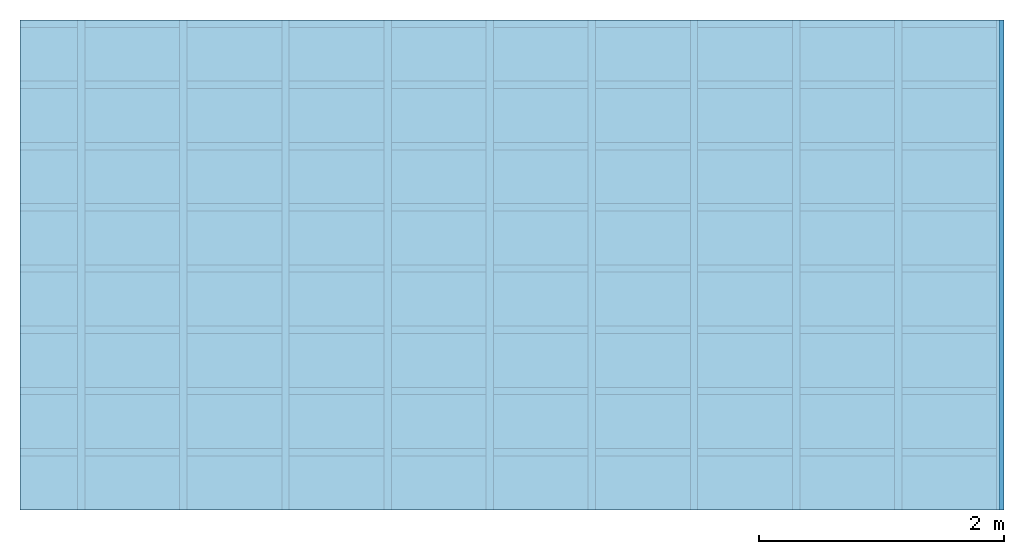
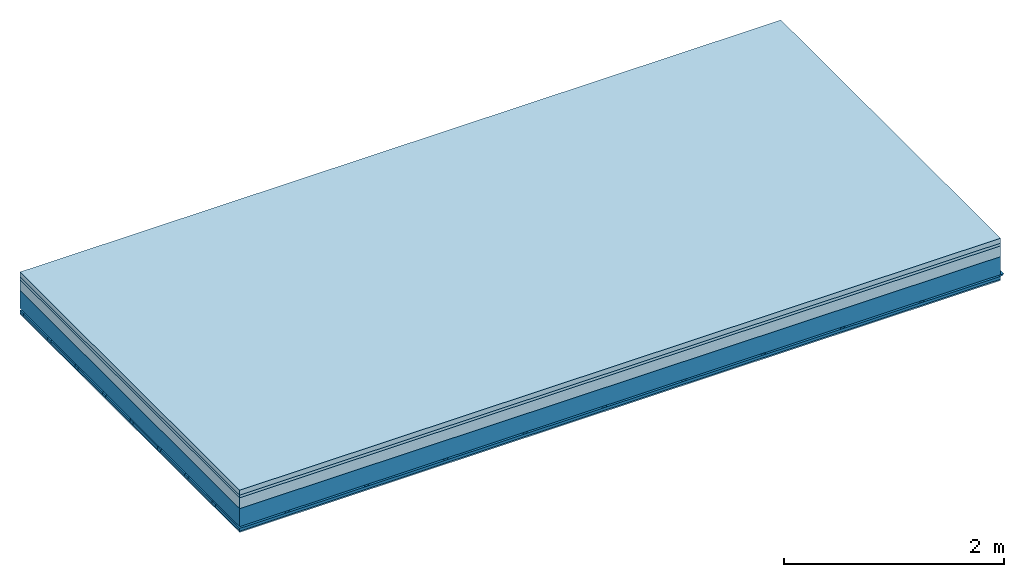
# One storey: 4 members, 4 plates, 1 element without a shape of its own.
"""IFC4 building model written with IfcOpenShell, lengths in metres."""

from ifc_helpers import new_model, si_unit, derived_unit, direction, frame, frame_2d, origin, origin_with_axes, place, context, project, spatial, polyline, rectangle, outline, extrude, material, layer, layer_set, type_object, element, aggregate, save


model = new_model("IFC4")

# Units and contexts
plan_context = context("Plan", 3, precision=1e-05, world=origin(), true_north=direction((0.0, 1.0)))
model_context = context("Model", 3, precision=1e-05, world=origin(), true_north=direction((0.0, 1.0)))
ifc_project = project(units=[si_unit("LENGTHUNIT", "METRE"), derived_unit("SOUNDPRESSUREUNIT", [(si_unit("PRESSUREUNIT", "PASCAL", prefix="MICRO"), 0)]), si_unit("ENERGYUNIT", "JOULE", prefix="MEGA"), si_unit("MASSUNIT", "GRAM", prefix="KILO"), derived_unit("THERMALTRANSMITTANCEUNIT", [(si_unit("POWERUNIT", "WATT"), 1), (si_unit("AREAUNIT", "SQUARE_METRE"), -1), (si_unit("THERMODYNAMICTEMPERATUREUNIT", "KELVIN"), -1)]), derived_unit("AREADENSITYUNIT", [(si_unit("MASSUNIT", "GRAM", prefix="KILO"), 1), (si_unit("AREAUNIT", "SQUARE_METRE"), -1)]), derived_unit("USERDEFINED", [(si_unit("ENERGYUNIT", "JOULE", prefix="MEGA"), 1), (si_unit("AREAUNIT", "SQUARE_METRE"), -1)])], contexts=[plan_context, model_context])

# Site, building, storey
site = spatial("IfcSite", under=ifc_project)
building_placement = place(None, origin())
building = spatial("IfcBuilding", under=site, at=building_placement)
storey_placement = place(building_placement, origin())
storey = spatial("IfcBuildingStorey", under=building, at=storey_placement)

# Slab, members, plates
ifc_material_1 = material(Category="04.005")
ifc_layer_1 = layer(ifc_material_1, 0.055, Name="On-material")
ifc_material_2 = material()
ifc_layer_2 = layer(ifc_material_2, 0.03, Name="Impact sound insulation")
ifc_material_3 = material(Category="03.011")
ifc_layer_3 = layer(ifc_material_3, 0.12, Name="on Supporting structure")
ifc_layer_4 = layer(None, 0.2, Name="Supporting structure")
ifc_material_4 = material(Name="no composite action")
ifc_layer_5 = layer(ifc_material_4, 0.0, Name="Bond")
ifc_layer_6 = layer(None, 0.02, Name="Coupling")
ifc_layer_7 = layer(None, 0.03, Name="Battens / profiles")
ifc_material_5 = material(Category="03.007")
ifc_layer_8 = layer(ifc_material_5, 0.015, Name="Ceiling covering 1st layer")
ifc_material_6 = material(Name="Glued joints")
ifc_layer_9 = layer(ifc_material_6, 0.0, Name="Surface / treatment")
ifc_layer_set = layer_set([ifc_layer_1, ifc_layer_2, ifc_layer_3, ifc_layer_4, ifc_layer_5, ifc_layer_6, ifc_layer_7, ifc_layer_8, ifc_layer_9])
slab_type = type_object("IfcSlabType", Name="A1245", PredefinedType="NOTDEFINED", material=ifc_layer_set)
slab_placement = place(None, frame((0.0, 0.0, 0.0), z_axis=(0.0, 0.0, -1.0), x_axis=(1.0, 0.0, 0.0)))
slab = element("IfcSlab", 1, at=slab_placement, inside=storey, type_object=slab_type, material=ifc_layer_set, Name="Slab #1")
ifc_material_7 = material()
member_1_placement = place(slab_placement, origin())
member_1 = element("IfcMember", 2, at=member_1_placement, material=ifc_material_7, Name="Supporting structure", context=plan_context, shape_type="SweptSolid", body=[
    extrude(rectangle(XDim=1.0, YDim=0.2, at=frame_2d((0.5, 0.1), x_axis=(1.0, 0.0))), frame((0.0, 4.0, 0.205), z_axis=(0.0, -1.0, 0.0), x_axis=(1.0, 0.0, 0.0)), (0.0, 0.0, 1.0), 4.0),
    extrude(rectangle(XDim=1.0, YDim=0.2, at=frame_2d((0.5, 0.1), x_axis=(1.0, 0.0))), frame((1.0, 4.0, 0.205), z_axis=(0.0, -1.0, 0.0), x_axis=(1.0, 0.0, 0.0)), (0.0, 0.0, 1.0), 4.0),
    extrude(rectangle(XDim=1.0, YDim=0.2, at=frame_2d((0.5, 0.1), x_axis=(1.0, 0.0))), frame((2.0, 4.0, 0.205), z_axis=(0.0, -1.0, 0.0), x_axis=(1.0, 0.0, 0.0)), (0.0, 0.0, 1.0), 4.0),
    extrude(rectangle(XDim=1.0, YDim=0.2, at=frame_2d((0.5, 0.1), x_axis=(1.0, 0.0))), frame((3.0, 4.0, 0.205), z_axis=(0.0, -1.0, 0.0), x_axis=(1.0, 0.0, 0.0)), (0.0, 0.0, 1.0), 4.0),
    extrude(rectangle(XDim=1.0, YDim=0.2, at=frame_2d((0.5, 0.1), x_axis=(1.0, 0.0))), frame((4.0, 4.0, 0.205), z_axis=(0.0, -1.0, 0.0), x_axis=(1.0, 0.0, 0.0)), (0.0, 0.0, 1.0), 4.0),
    extrude(rectangle(XDim=1.0, YDim=0.2, at=frame_2d((0.5, 0.1), x_axis=(1.0, 0.0))), frame((5.0, 4.0, 0.205), z_axis=(0.0, -1.0, 0.0), x_axis=(1.0, 0.0, 0.0)), (0.0, 0.0, 1.0), 4.0),
    extrude(rectangle(XDim=1.0, YDim=0.2, at=frame_2d((0.5, 0.1), x_axis=(1.0, 0.0))), frame((6.0, 4.0, 0.205), z_axis=(0.0, -1.0, 0.0), x_axis=(1.0, 0.0, 0.0)), (0.0, 0.0, 1.0), 4.0),
    extrude(rectangle(XDim=1.0, YDim=0.2, at=frame_2d((0.5, 0.1), x_axis=(1.0, 0.0))), frame((7.0, 4.0, 0.205), z_axis=(0.0, -1.0, 0.0), x_axis=(1.0, 0.0, 0.0)), (0.0, 0.0, 1.0), 4.0),
])
ifc_material_8 = material()
member_2_placement = place(slab_placement, origin())
member_2 = element("IfcMember", 3, at=member_2_placement, material=ifc_material_8, Name="Coupling", context=plan_context, shape_type="SweptSolid", body=[
    extrude(outline(polyline([(0.0, 0.0), (0.06, 0.0), (0.04, 0.02), (0.02, 0.02), (0.0, 0.0)])), frame((0.47, 4.0, 0.405), z_axis=(0.0, -1.0, 0.0), x_axis=(1.0, 0.0, 0.0)), (0.0, 0.0, 1.0), 4.0),
    extrude(outline(polyline([(0.0, 0.0), (0.06, 0.0), (0.04, 0.02), (0.02, 0.02), (0.0, 0.0)])), frame((1.304, 4.0, 0.405), z_axis=(0.0, -1.0, 0.0), x_axis=(1.0, 0.0, 0.0)), (0.0, 0.0, 1.0), 4.0),
    extrude(outline(polyline([(0.0, 0.0), (0.06, 0.0), (0.04, 0.02), (0.02, 0.02), (0.0, 0.0)])), frame((2.138, 4.0, 0.405), z_axis=(0.0, -1.0, 0.0), x_axis=(1.0, 0.0, 0.0)), (0.0, 0.0, 1.0), 4.0),
    extrude(outline(polyline([(0.0, 0.0), (0.06, 0.0), (0.04, 0.02), (0.02, 0.02), (0.0, 0.0)])), frame((2.972, 4.0, 0.405), z_axis=(0.0, -1.0, 0.0), x_axis=(1.0, 0.0, 0.0)), (0.0, 0.0, 1.0), 4.0),
    extrude(outline(polyline([(0.0, 0.0), (0.06, 0.0), (0.04, 0.02), (0.02, 0.02), (0.0, 0.0)])), frame((3.806, 4.0, 0.405), z_axis=(0.0, -1.0, 0.0), x_axis=(1.0, 0.0, 0.0)), (0.0, 0.0, 1.0), 4.0),
    extrude(outline(polyline([(0.0, 0.0), (0.06, 0.0), (0.04, 0.02), (0.02, 0.02), (0.0, 0.0)])), frame((4.64, 4.0, 0.405), z_axis=(0.0, -1.0, 0.0), x_axis=(1.0, 0.0, 0.0)), (0.0, 0.0, 1.0), 4.0),
    extrude(outline(polyline([(0.0, 0.0), (0.06, 0.0), (0.04, 0.02), (0.02, 0.02), (0.0, 0.0)])), frame((5.474, 4.0, 0.405), z_axis=(0.0, -1.0, 0.0), x_axis=(1.0, 0.0, 0.0)), (0.0, 0.0, 1.0), 4.0),
    extrude(outline(polyline([(0.0, 0.0), (0.06, 0.0), (0.04, 0.02), (0.02, 0.02), (0.0, 0.0)])), frame((6.308, 4.0, 0.405), z_axis=(0.0, -1.0, 0.0), x_axis=(1.0, 0.0, 0.0)), (0.0, 0.0, 1.0), 4.0),
    extrude(outline(polyline([(0.0, 0.0), (0.06, 0.0), (0.04, 0.02), (0.02, 0.02), (0.0, 0.0)])), frame((7.142, 4.0, 0.405), z_axis=(0.0, -1.0, 0.0), x_axis=(1.0, 0.0, 0.0)), (0.0, 0.0, 1.0), 4.0),
    extrude(outline(polyline([(0.0, 0.0), (0.06, 0.0), (0.04, 0.02), (0.02, 0.02), (0.0, 0.0)])), frame((7.976, 4.0, 0.405), z_axis=(0.0, -1.0, 0.0), x_axis=(1.0, 0.0, 0.0)), (0.0, 0.0, 1.0), 4.0),
])
ifc_material_9 = material()
member_3_placement = place(slab_placement, origin())
member_3 = element("IfcMember", 4, at=member_3_placement, material=ifc_material_9, Name="Battens / profiles", context=plan_context, shape_type="SweptSolid", body=[
    extrude(rectangle(XDim=0.06, YDim=0.03, at=frame_2d((0.03, 0.015), x_axis=(1.0, 0.0))), frame((0.0, 0.0, 0.425), z_axis=(1.0, 0.0, 0.0), x_axis=(0.0, 1.0, 0.0)), (0.0, 0.0, 1.0), 8.0),
    extrude(rectangle(XDim=0.06, YDim=0.03, at=frame_2d((0.03, 0.015), x_axis=(1.0, 0.0))), frame((0.0, 0.5, 0.425), z_axis=(1.0, 0.0, 0.0), x_axis=(0.0, 1.0, 0.0)), (0.0, 0.0, 1.0), 8.0),
    extrude(rectangle(XDim=0.06, YDim=0.03, at=frame_2d((0.03, 0.015), x_axis=(1.0, 0.0))), frame((0.0, 1.0, 0.425), z_axis=(1.0, 0.0, 0.0), x_axis=(0.0, 1.0, 0.0)), (0.0, 0.0, 1.0), 8.0),
    extrude(rectangle(XDim=0.06, YDim=0.03, at=frame_2d((0.03, 0.015), x_axis=(1.0, 0.0))), frame((0.0, 1.5, 0.425), z_axis=(1.0, 0.0, 0.0), x_axis=(0.0, 1.0, 0.0)), (0.0, 0.0, 1.0), 8.0),
    extrude(rectangle(XDim=0.06, YDim=0.03, at=frame_2d((0.03, 0.015), x_axis=(1.0, 0.0))), frame((0.0, 2.0, 0.425), z_axis=(1.0, 0.0, 0.0), x_axis=(0.0, 1.0, 0.0)), (0.0, 0.0, 1.0), 8.0),
    extrude(rectangle(XDim=0.06, YDim=0.03, at=frame_2d((0.03, 0.015), x_axis=(1.0, 0.0))), frame((0.0, 2.5, 0.425), z_axis=(1.0, 0.0, 0.0), x_axis=(0.0, 1.0, 0.0)), (0.0, 0.0, 1.0), 8.0),
    extrude(rectangle(XDim=0.06, YDim=0.03, at=frame_2d((0.03, 0.015), x_axis=(1.0, 0.0))), frame((0.0, 3.0, 0.425), z_axis=(1.0, 0.0, 0.0), x_axis=(0.0, 1.0, 0.0)), (0.0, 0.0, 1.0), 8.0),
    extrude(rectangle(XDim=0.06, YDim=0.03, at=frame_2d((0.03, 0.015), x_axis=(1.0, 0.0))), frame((0.0, 3.5, 0.425), z_axis=(1.0, 0.0, 0.0), x_axis=(0.0, 1.0, 0.0)), (0.0, 0.0, 1.0), 8.0),
])
ifc_material_10 = material()
member_4_placement = place(slab_placement, origin())
member_4 = element("IfcMember", 5, at=member_4_placement, material=ifc_material_10, Name="Cavity", context=plan_context, shape_type="SweptSolid", body=[
    extrude(rectangle(XDim=0.44, YDim=0.03, at=frame_2d((0.22, 0.015), x_axis=(1.0, 0.0))), frame((0.0, 0.06, 0.425), z_axis=(1.0, 0.0, 0.0), x_axis=(0.0, 1.0, 0.0)), (0.0, 0.0, 1.0), 8.0),
    extrude(rectangle(XDim=0.44, YDim=0.03, at=frame_2d((0.22, 0.015), x_axis=(1.0, 0.0))), frame((0.0, 0.56, 0.425), z_axis=(1.0, 0.0, 0.0), x_axis=(0.0, 1.0, 0.0)), (0.0, 0.0, 1.0), 8.0),
    extrude(rectangle(XDim=0.44, YDim=0.03, at=frame_2d((0.22, 0.015), x_axis=(1.0, 0.0))), frame((0.0, 1.06, 0.425), z_axis=(1.0, 0.0, 0.0), x_axis=(0.0, 1.0, 0.0)), (0.0, 0.0, 1.0), 8.0),
    extrude(rectangle(XDim=0.44, YDim=0.03, at=frame_2d((0.22, 0.015), x_axis=(1.0, 0.0))), frame((0.0, 1.56, 0.425), z_axis=(1.0, 0.0, 0.0), x_axis=(0.0, 1.0, 0.0)), (0.0, 0.0, 1.0), 8.0),
    extrude(rectangle(XDim=0.44, YDim=0.03, at=frame_2d((0.22, 0.015), x_axis=(1.0, 0.0))), frame((0.0, 2.06, 0.425), z_axis=(1.0, 0.0, 0.0), x_axis=(0.0, 1.0, 0.0)), (0.0, 0.0, 1.0), 8.0),
    extrude(rectangle(XDim=0.44, YDim=0.03, at=frame_2d((0.22, 0.015), x_axis=(1.0, 0.0))), frame((0.0, 2.56, 0.425), z_axis=(1.0, 0.0, 0.0), x_axis=(0.0, 1.0, 0.0)), (0.0, 0.0, 1.0), 8.0),
    extrude(rectangle(XDim=0.44, YDim=0.03, at=frame_2d((0.22, 0.015), x_axis=(1.0, 0.0))), frame((0.0, 3.06, 0.425), z_axis=(1.0, 0.0, 0.0), x_axis=(0.0, 1.0, 0.0)), (0.0, 0.0, 1.0), 8.0),
    extrude(rectangle(XDim=0.44, YDim=0.03, at=frame_2d((0.22, 0.015), x_axis=(1.0, 0.0))), frame((0.0, 3.56, 0.425), z_axis=(1.0, 0.0, 0.0), x_axis=(0.0, 1.0, 0.0)), (0.0, 0.0, 1.0), 8.0),
])
plate_1_placement = place(slab_placement, origin())
plate_1 = element("IfcPlate", 6, at=plate_1_placement, material=ifc_material_1, Name="On-material", context=plan_context, shape_type="SweptSolid", body=[
    extrude(rectangle(XDim=8.0, YDim=4.0, at=frame_2d((4.0, 2.0), x_axis=(1.0, 0.0))), origin_with_axes(), (0.0, 0.0, 1.0), 0.055),
])
plate_2_placement = place(slab_placement, origin())
plate_2 = element("IfcPlate", 7, at=plate_2_placement, material=ifc_material_2, Name="Impact sound insulation", context=plan_context, shape_type="SweptSolid", body=[
    extrude(rectangle(XDim=8.0, YDim=4.0, at=frame_2d((4.0, 2.0), x_axis=(1.0, 0.0))), frame((0.0, 0.0, 0.055), z_axis=(0.0, 0.0, 1.0), x_axis=(1.0, 0.0, 0.0)), (0.0, 0.0, 1.0), 0.03),
])
plate_3_placement = place(slab_placement, origin())
plate_3 = element("IfcPlate", 8, at=plate_3_placement, material=ifc_material_3, Name="on Supporting structure", context=plan_context, shape_type="SweptSolid", body=[
    extrude(rectangle(XDim=8.0, YDim=4.0, at=frame_2d((4.0, 2.0), x_axis=(1.0, 0.0))), frame((0.0, 0.0, 0.085), z_axis=(0.0, 0.0, 1.0), x_axis=(1.0, 0.0, 0.0)), (0.0, 0.0, 1.0), 0.12),
])
plate_4_placement = place(slab_placement, origin())
plate_4 = element("IfcPlate", 9, at=plate_4_placement, material=ifc_material_5, Name="Ceiling covering 1st layer", context=plan_context, shape_type="SweptSolid", body=[
    extrude(rectangle(XDim=8.0, YDim=4.0, at=frame_2d((4.0, 2.0), x_axis=(1.0, 0.0))), frame((0.0, 0.0, 0.455), z_axis=(0.0, 0.0, 1.0), x_axis=(1.0, 0.0, 0.0)), (0.0, 0.0, 1.0), 0.015),
])
aggregate(slab, [plate_1, plate_2, plate_3, member_1, member_2, member_3, member_4, plate_4])

save(model, "model.ifc")
